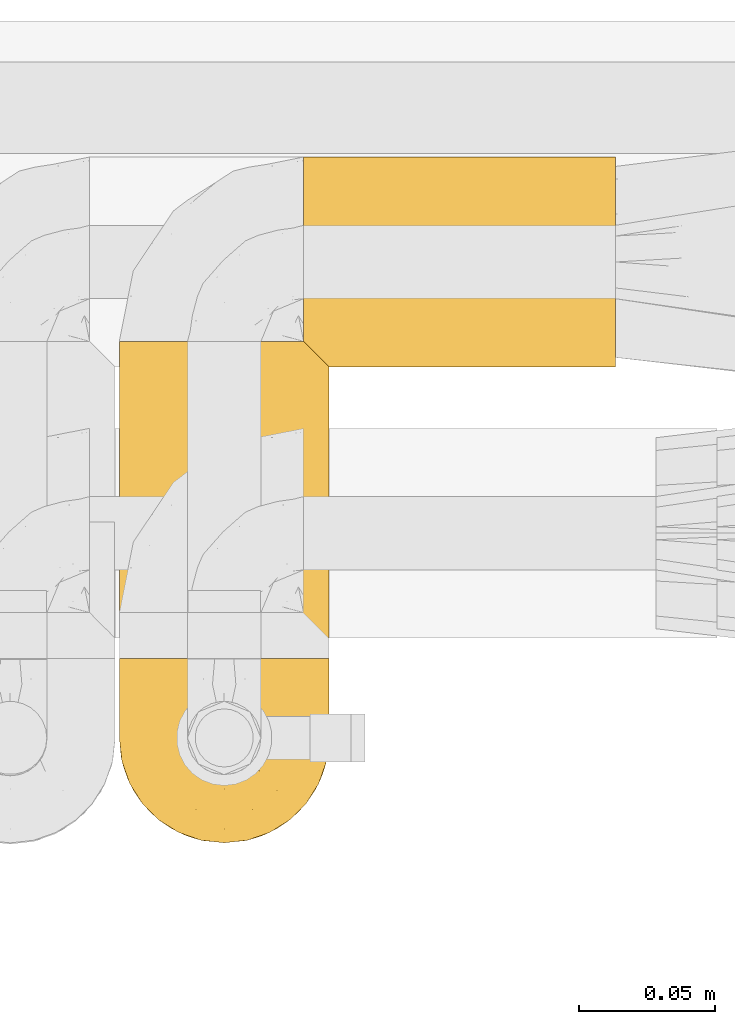
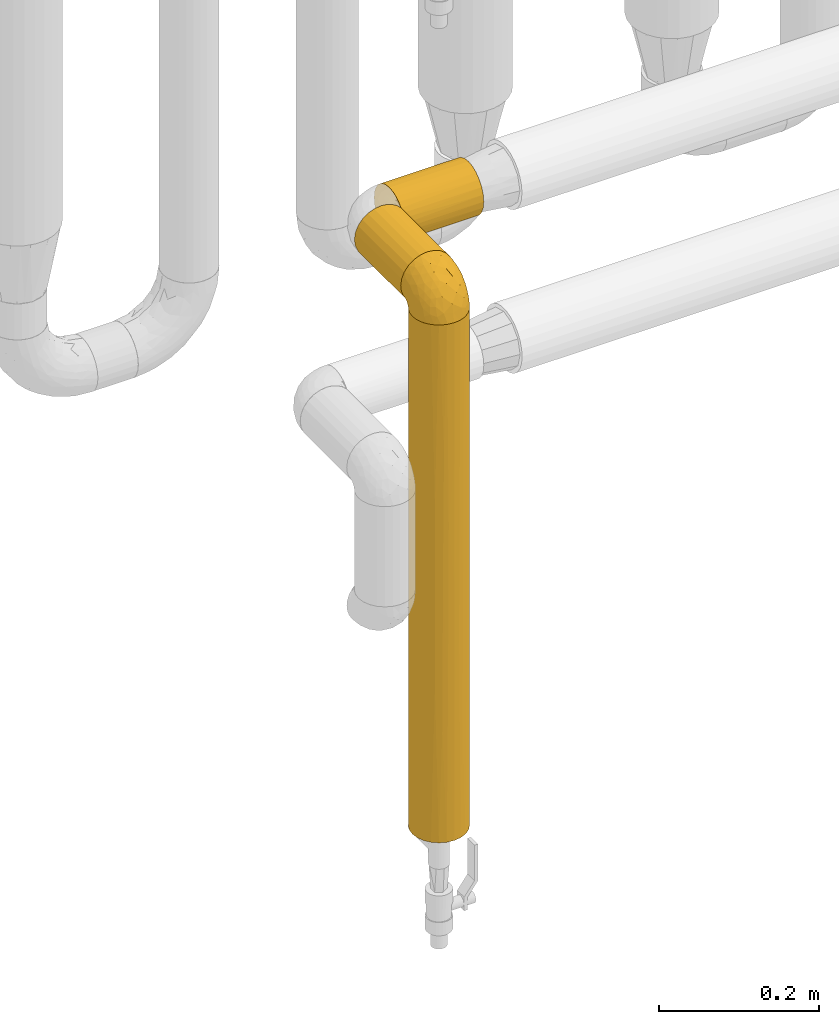
# One storey, part 467 of 827: 4 coverings.
"""IFC2X3 building model written with IfcOpenShell, lengths in millimetres."""

from ifc_helpers import new_model, entity, si_unit, converted_unit, derived_unit, direction, frame, origin, place, context, subcontext, project, spatial, faceted_brep, element, save


model = new_model("IFC2X3")

# Units and contexts
model_context = context("Model", 3, precision=0.01, world=origin(), true_north=direction((6.12303176911189e-17, 1.0)))
body_context = subcontext(model_context, "Body", "Model", "MODEL_VIEW")
ifc_project = project(units=[si_unit("LENGTHUNIT", "METRE", prefix="MILLI"), si_unit("AREAUNIT", "SQUARE_METRE"), si_unit("VOLUMEUNIT", "CUBIC_METRE"), converted_unit("PLANEANGLEUNIT", "DEGREE", entity("IfcRatioMeasure", 0.0174532925199433), si_unit("PLANEANGLEUNIT", "RADIAN"), dimensions=[0, 0, 0, 0, 0, 0, 0]), si_unit("MASSUNIT", "GRAM", prefix="KILO"), derived_unit("MASSDENSITYUNIT", [(si_unit("MASSUNIT", "GRAM", prefix="KILO"), 1), (si_unit("LENGTHUNIT", "METRE"), -3)]), derived_unit("MOMENTOFINERTIAUNIT", [(si_unit("LENGTHUNIT", "METRE"), 4)]), si_unit("TIMEUNIT", "SECOND"), si_unit("FREQUENCYUNIT", "HERTZ"), si_unit("THERMODYNAMICTEMPERATUREUNIT", "DEGREE_CELSIUS"), derived_unit("THERMALTRANSMITTANCEUNIT", [(si_unit("MASSUNIT", "GRAM", prefix="KILO"), 1), (si_unit("THERMODYNAMICTEMPERATUREUNIT", "KELVIN"), -1), (si_unit("TIMEUNIT", "SECOND"), -3)]), derived_unit("VOLUMETRICFLOWRATEUNIT", [(si_unit("LENGTHUNIT", "METRE"), 3), (si_unit("TIMEUNIT", "SECOND"), -1)]), derived_unit("MASSFLOWRATEUNIT", [(si_unit("MASSUNIT", "GRAM", prefix="KILO"), 1), (si_unit("TIMEUNIT", "SECOND"), -1)]), derived_unit("ROTATIONALFREQUENCYUNIT", [(si_unit("TIMEUNIT", "SECOND"), -1)]), si_unit("ELECTRICCURRENTUNIT", "AMPERE"), si_unit("ELECTRICVOLTAGEUNIT", "VOLT"), si_unit("POWERUNIT", "WATT"), si_unit("FORCEUNIT", "NEWTON", prefix="KILO"), si_unit("ILLUMINANCEUNIT", "LUX"), si_unit("LUMINOUSFLUXUNIT", "LUMEN"), si_unit("LUMINOUSINTENSITYUNIT", "CANDELA"), derived_unit("USERDEFINED", [(si_unit("MASSUNIT", "GRAM", prefix="KILO"), -1), (si_unit("LENGTHUNIT", "METRE"), -2), (si_unit("TIMEUNIT", "SECOND"), 3), (si_unit("LUMINOUSFLUXUNIT", "LUMEN"), 1)]), derived_unit("LINEARVELOCITYUNIT", [(si_unit("LENGTHUNIT", "METRE"), 1), (si_unit("TIMEUNIT", "SECOND"), -1)]), si_unit("PRESSUREUNIT", "PASCAL"), derived_unit("USERDEFINED", [(si_unit("LENGTHUNIT", "METRE"), -2), (si_unit("MASSUNIT", "GRAM", prefix="KILO"), 1), (si_unit("TIMEUNIT", "SECOND"), -2)]), derived_unit("LINEARFORCEUNIT", [(si_unit("MASSUNIT", "GRAM", prefix="KILO"), 1), (si_unit("LENGTHUNIT", "METRE"), 1), (si_unit("TIMEUNIT", "SECOND"), -2), (si_unit("LENGTHUNIT", "METRE"), -1)]), derived_unit("PLANARFORCEUNIT", [(si_unit("MASSUNIT", "GRAM", prefix="KILO"), 1), (si_unit("LENGTHUNIT", "METRE"), 1), (si_unit("TIMEUNIT", "SECOND"), -2), (si_unit("LENGTHUNIT", "METRE"), -2)])], contexts=[model_context])

# Site, building, storey
site_placement = place(None, origin())
site = spatial("IfcSite", under=ifc_project, at=site_placement, CompositionType="ELEMENT")
building_placement = place(site_placement, origin())
building = spatial("IfcBuilding", under=site, at=building_placement, CompositionType="ELEMENT")
storey_placement = place(building_placement, frame((0.0, 0.0, 28200.0)))
storey = spatial("IfcBuildingStorey", under=building, at=storey_placement, Name="08", CompositionType="ELEMENT", Elevation=28200.0)

# Coverings
covering_1_placement = place(storey_placement, frame((58529.6, 16332.35, 1210.0)))
element("IfcCovering", 1, at=covering_1_placement, inside=storey, Name=":ADSK_", ObjectType=":ADSK_", PredefinedType="INSULATION", context=body_context, shape_type="Brep", body=[
    faceted_brep([(9.31, 1.6, 16.91), (14.94, 1.6, 10.9), (65.05, 1.6, 10.9), (70.68, 1.6, 16.91), (74.9, 1.6, 23.98), (77.51, 1.6, 31.79), (78.4, 1.6, 40.0), (77.09, 1.6, 49.93), (73.25, 1.6, 59.2), (67.15, 1.6, 67.15), (59.2, 1.6, 73.25), (49.93, 1.6, 77.09), (40.0, 1.6, 78.4), (30.06, 1.6, 77.09), (20.8, 1.6, 73.25), (12.84, 1.6, 67.15), (6.74, 1.6, 59.2), (2.9, 1.6, 49.93), (1.6, 1.6, 40.0), (2.48, 1.6, 31.79), (5.09, 1.6, 23.98), (30.06, 117.77, 2.9), (20.8, 117.77, 6.74), (12.84, 117.77, 12.84), (6.74, 117.77, 20.8), (2.9, 117.77, 30.06), (1.6, 117.77, 40.0), (2.9, 117.77, 49.93), (6.74, 117.77, 59.2), (12.84, 117.77, 67.15), (20.8, 117.77, 73.25), (30.06, 117.77, 77.09), (40.0, 117.77, 78.4), (48.2, 117.77, 77.51), (56.01, 117.77, 74.9), (63.08, 117.77, 70.68), (69.1, 117.77, 65.05), (69.1, 117.77, 14.94), (63.08, 117.77, 9.31), (56.01, 117.77, 5.09), (48.2, 117.77, 2.48), (40.0, 117.77, 1.6), (26.63, 8.5, 4.0), (33.21, 10.29, 2.2), (40.0, 10.9, 1.6), (20.48, 5.57, 6.92), (46.78, 10.29, 2.2), (53.36, 8.5, 4.0), (59.51, 5.57, 6.92), (73.07, 113.8, 20.48), (76.0, 110.87, 26.63), (77.79, 109.08, 33.21), (78.4, 108.47, 40.0), (77.79, 109.08, 46.78), (76.0, 110.87, 53.36), (73.07, 113.8, 59.51)], [[[0, 1, 2, 3, 4, 5, 6, 7, 8, 9, 10, 11, 12, 13, 14, 15, 16, 17, 18, 19, 20]], [[21, 22, 23, 24, 25, 26, 27, 28, 29, 30, 31, 32, 33, 34, 35, 36, 37, 38, 39, 40, 41]], [[26, 25, 19]], [[25, 24, 20]], [[0, 24, 23]], [[19, 18, 26]], [[20, 19, 25]], [[24, 0, 20]], [[23, 1, 0]], [[42, 22, 21]], [[21, 41, 43]], [[44, 43, 41]], [[45, 1, 22]], [[43, 42, 21]], [[45, 22, 42]], [[22, 1, 23]], [[46, 41, 40]], [[47, 40, 39]], [[48, 39, 38]], [[46, 44, 41]], [[48, 47, 39]], [[2, 48, 38]], [[46, 40, 47]], [[38, 37, 2]], [[37, 49, 3]], [[50, 51, 5]], [[49, 50, 4]], [[3, 49, 4]], [[51, 6, 5]], [[5, 4, 50]], [[6, 51, 52]], [[37, 3, 2]], [[53, 54, 7]], [[55, 36, 8]], [[54, 55, 8]], [[52, 53, 6]], [[6, 53, 7]], [[54, 8, 7]], [[36, 9, 8]], [[10, 35, 34]], [[11, 34, 33]], [[12, 33, 32]], [[9, 35, 10]], [[10, 34, 11]], [[33, 12, 11]], [[35, 9, 36]], [[13, 12, 32, 31]], [[14, 13, 31, 30]], [[30, 29, 15, 14]], [[17, 16, 28, 27]], [[18, 17, 27, 26]], [[29, 28, 16, 15]], [[45, 42, 43, 44, 46, 47, 48, 2, 1]], [[36, 55, 54, 53, 52, 51, 50, 49, 37]]]),
])
covering_2_placement = place(storey_placement, frame((58529.55, 16264.8, 1219.3)))
element("IfcCovering", 2, at=covering_2_placement, inside=storey, Name=":ADSK_", ObjectType=":ADSK_", PredefinedType="INSULATION", context=body_context, shape_type="Brep", body=[
    faceted_brep([(74.68, 23.36, 1.6), (70.1, 16.07, 1.6), (64.01, 9.98, 1.6), (56.72, 5.4, 1.6), (48.6, 2.56, 1.6), (40.05, 1.6, 1.6), (31.49, 2.56, 1.6), (23.36, 5.41, 1.6), (16.07, 9.99, 1.6), (9.98, 16.08, 1.6), (5.4, 23.37, 1.6), (2.56, 31.49, 1.6), (1.6, 40.05, 1.6), (2.46, 48.15, 1.6), (5.01, 55.88, 1.6), (9.13, 62.9, 1.6), (14.62, 68.89, 1.6), (16.82, 68.89, 1.6), (18.56, 68.89, 1.6), (20.52, 68.89, 1.6), (22.49, 68.89, 1.6), (24.46, 68.89, 1.6), (26.42, 68.89, 1.6), (28.39, 68.89, 1.6), (30.36, 68.89, 1.6), (32.55, 68.89, 1.6), (34.75, 68.89, 1.6), (36.94, 68.89, 1.6), (39.13, 68.89, 1.6), (41.33, 68.89, 1.6), (43.52, 68.89, 1.6), (45.72, 68.89, 1.6), (47.91, 68.89, 1.6), (50.11, 68.89, 1.6), (52.3, 68.89, 1.6), (54.49, 68.89, 1.6), (56.69, 68.89, 1.6), (58.88, 68.89, 1.6), (61.08, 68.89, 1.6), (63.27, 68.89, 1.6), (65.47, 68.89, 1.6), (70.97, 62.89, 1.6), (75.09, 55.86, 1.6), (77.64, 48.13, 1.6), (78.5, 40.05, 1.6), (77.53, 31.49, 1.6), (14.62, 69.15, 1.85), (9.12, 69.15, 7.85), (5.0, 69.15, 14.87), (2.46, 69.15, 22.6), (1.6, 69.15, 30.7), (2.91, 69.15, 40.65), (6.75, 69.15, 49.92), (12.86, 69.15, 57.88), (20.82, 69.15, 63.99), (30.09, 69.15, 67.84), (40.05, 69.15, 69.15), (50.0, 69.15, 67.84), (59.27, 69.15, 63.99), (67.23, 69.15, 57.88), (73.34, 69.15, 49.92), (77.19, 69.15, 40.65), (78.5, 69.15, 30.7), (77.63, 69.15, 22.6), (75.09, 69.15, 14.87), (70.97, 69.15, 7.85), (65.47, 69.15, 1.85), (63.27, 69.15, 1.85), (62.29, 69.15, 1.85), (60.7, 69.15, 1.85), (59.11, 69.15, 1.85), (57.52, 69.15, 1.85), (55.93, 69.15, 1.85), (54.34, 69.15, 1.85), (52.76, 69.15, 1.85), (51.17, 69.15, 1.85), (49.58, 69.15, 1.85), (47.99, 69.15, 1.85), (46.4, 69.15, 1.85), (44.81, 69.15, 1.85), (43.22, 69.15, 1.85), (41.63, 69.15, 1.85), (40.05, 69.15, 1.85), (38.46, 69.15, 1.85), (36.87, 69.15, 1.85), (35.28, 69.15, 1.85), (33.69, 69.15, 1.85), (32.1, 69.15, 1.85), (30.51, 69.15, 1.85), (28.92, 69.15, 1.85), (27.33, 69.15, 1.85), (25.37, 69.15, 1.85), (23.4, 69.15, 1.85), (21.21, 69.15, 1.85), (19.01, 69.15, 1.85), (16.82, 69.15, 1.85), (42.32, 68.96, 1.77), (44.02, 68.97, 1.78), (47.13, 68.97, 1.77), (48.74, 68.97, 1.77), (23.57, 68.95, 1.76), (25.13, 68.96, 1.77), (61.34, 68.98, 1.79), (22.02, 68.97, 1.78), (29.72, 68.97, 1.78), (56.73, 68.98, 1.78), (55.14, 68.97, 1.78), (37.66, 68.97, 1.78), (64.12, 68.94, 1.74), (28.13, 68.98, 1.78), (26.62, 68.98, 1.78), (31.46, 68.96, 1.77), (16.16, 68.97, 1.78), (39.16, 68.98, 1.78), (50.37, 68.98, 1.78), (17.69, 68.97, 1.77), (19.17, 68.96, 1.77), (62.78, 68.97, 1.77), (58.35, 68.97, 1.78), (45.53, 68.98, 1.78), (59.91, 68.96, 1.77), (65.47, 68.97, 1.77), (65.47, 68.94, 1.72), (65.47, 68.92, 1.66), (14.62, 68.97, 1.77), (14.62, 69.02, 1.8), (14.62, 69.08, 1.82), (20.59, 68.98, 1.79), (32.99, 68.97, 1.78), (34.48, 68.98, 1.79), (51.91, 68.97, 1.78), (65.47, 69.08, 1.82), (65.47, 69.02, 1.8), (53.48, 68.96, 1.76), (14.62, 68.92, 1.66), (14.62, 68.94, 1.72), (40.77, 68.97, 1.78), (35.97, 68.96, 1.77), (7.84, 67.02, 9.41), (3.53, 63.33, 17.65), (8.32, 64.61, 7.41), (1.6, 49.27, 21.47), (2.19, 51.4, 15.21), (1.6, 43.94, 16.15), (1.6, 61.87, 28.75), (4.57, 61.54, 13.67), (3.96, 57.95, 12.79), (2.28, 56.12, 19.18), (1.6, 63.4, 29.16), (7.69, 65.41, 9.04), (3.53, 53.1, 7.41), (8.32, 63.04, 5.74), (7.84, 61.33, 3.72), (1.6, 41.99, 8.87), (1.6, 54.6, 26.8), (4.34, 56.6, 9.53), (1.6, 41.58, 7.34), (29.63, 13.72, 37.63), (27.34, 5.82, 17.92), (40.05, 6.74, 27.45), (2.39, 58.82, 37.01), (2.43, 51.58, 34.22), (9.07, 42.09, 45.87), (16.64, 46.12, 56.57), (9.54, 55.56, 52.31), (4.52, 52.38, 42.07), (4.52, 61.54, 44.74), (7.49, 23.76, 21.49), (7.49, 20.5, 11.02), (12.85, 14.64, 15.64), (2.35, 41.77, 26.02), (22.66, 16.28, 36.59), (32.9, 49.4, 65.49), (25.33, 52.34, 63.99), (40.05, 4.3, 15.2), (16.64, 58.67, 60.27), (19.99, 25.26, 45.25), (16.37, 20.17, 35.21), (3.26, 34.7, 22.52), (3.75, 28.67, 12.03), (19.58, 8.62, 13.32), (7.5, 33.37, 35.9), (4.04, 41.35, 33.87), (13.94, 17.15, 25.73), (19.58, 12.68, 26.34), (28.21, 21.47, 46.78), (24.75, 41.11, 59.54), (31.42, 37.53, 60.18), (26.2, 30.64, 53.93), (33.36, 26.66, 53.36), (40.05, 21.38, 49.36), (40.05, 14.06, 38.4), (40.05, 55.54, 66.44), (16.14, 35.17, 50.09), (12.85, 29.04, 41.08), (10.47, 24.34, 31.14), (6.49, 29.33, 28.19), (40.05, 43.3, 64.0), (40.05, 32.34, 56.68), (75.57, 57.75, 43.9), (47.37, 49.41, 65.46), (52.91, 27.85, 52.22), (50.46, 13.7, 37.61), (67.23, 14.63, 15.64), (60.5, 8.61, 13.31), (70.55, 48.85, 50.02), (63.45, 54.13, 59.28), (62.61, 37.84, 53.05), (72.6, 23.75, 21.48), (72.6, 20.49, 11.01), (76.34, 28.66, 12.03), (59.34, 20.83, 41.02), (77.76, 55.15, 35.39), (78.5, 54.6, 26.8), (78.5, 61.87, 28.75), (78.5, 41.58, 7.34), (53.16, 57.58, 65.81), (70.55, 59.91, 53.28), (48.88, 36.94, 59.8), (54.76, 45.72, 61.82), (52.74, 5.82, 17.91), (71.93, 37.91, 41.4), (75.79, 50.18, 40.48), (60.5, 12.67, 26.34), (77.86, 49.29, 31.68), (77.64, 42.64, 27.68), (78.5, 43.94, 16.15), (78.5, 49.27, 21.47), (67.23, 19.45, 28.05), (76.82, 34.7, 22.54), (78.5, 41.99, 8.87), (77.8, 62.29, 37.3), (67.23, 29.01, 41.07), (73.2, 31.47, 32.24), (67.66, 37.18, 47.4), (75.99, 43.45, 35.77), (76.57, 63.33, 17.65), (73.21, 67.23, 11.06), (71.93, 66.07, 8.55), (71.07, 65.22, 6.63), (75.09, 61.99, 12.77), (76.13, 57.95, 12.79), (76.57, 53.09, 7.41), (77.69, 56.84, 18.97), (72.26, 61.33, 3.72), (71.77, 63.06, 5.76), (77.9, 51.41, 15.21), (75.75, 56.61, 9.52)], [[[0, 1, 2, 3, 4, 5, 6, 7, 8, 9, 10, 11, 12, 13, 14, 15, 16, 17, 18, 19, 20, 21, 22, 23, 24, 25, 26, 27, 28, 29, 30, 31, 32, 33, 34, 35, 36, 37, 38, 39, 40, 41, 42, 43, 44, 45]], [[46, 47, 48, 49, 50, 51, 52, 53, 54, 55, 56, 57, 58, 59, 60, 61, 62, 63, 64, 65, 66, 67, 68, 69, 70, 71, 72, 73, 74, 75, 76, 77, 78, 79, 80, 81, 82, 83, 84, 85, 86, 87, 88, 89, 90, 91, 92, 93, 94, 95]], [[96, 97, 30]], [[98, 77, 99]], [[100, 101, 21]], [[69, 68, 102]], [[20, 19, 103]], [[24, 23, 104]], [[20, 103, 100]], [[72, 105, 106]], [[84, 83, 107]], [[89, 88, 104]], [[108, 67, 66]], [[109, 110, 90]], [[111, 25, 24]], [[112, 17, 16]], [[82, 113, 83]], [[109, 23, 22]], [[114, 76, 75]], [[105, 36, 106]], [[104, 111, 24]], [[18, 115, 116]], [[97, 96, 80]], [[67, 108, 117]], [[105, 71, 118]], [[31, 97, 119]], [[102, 120, 69]], [[108, 121, 122, 123, 40]], [[112, 95, 115]], [[17, 115, 18]], [[94, 116, 115]], [[117, 68, 67]], [[38, 117, 39]], [[112, 124, 125, 126, 46]], [[17, 112, 115]], [[70, 120, 118]], [[39, 117, 108]], [[120, 38, 37]], [[120, 37, 118]], [[120, 70, 69]], [[116, 94, 127]], [[128, 86, 129]], [[117, 38, 102]], [[74, 130, 75]], [[99, 33, 32]], [[115, 95, 94]], [[39, 108, 40]], [[108, 66, 131, 132, 121]], [[105, 72, 71]], [[118, 37, 36]], [[71, 70, 118]], [[35, 106, 36]], [[36, 105, 118]], [[35, 133, 106]], [[74, 73, 133]], [[106, 133, 73]], [[99, 114, 33]], [[133, 35, 34]], [[73, 72, 106]], [[95, 112, 46]], [[112, 16, 134, 135, 124]], [[130, 114, 75]], [[99, 76, 114]], [[114, 130, 33]], [[34, 33, 130]], [[78, 77, 98]], [[98, 119, 78]], [[130, 133, 34]], [[133, 130, 74]], [[79, 97, 80]], [[98, 99, 32]], [[98, 32, 31]], [[77, 76, 99]], [[97, 79, 119]], [[136, 96, 29]], [[30, 97, 31]], [[136, 29, 28]], [[81, 80, 96]], [[29, 96, 30]], [[31, 119, 98]], [[119, 79, 78]], [[96, 136, 81]], [[82, 81, 136]], [[113, 107, 83]], [[84, 107, 137]], [[107, 27, 137]], [[113, 28, 107]], [[27, 107, 28]], [[85, 84, 137]], [[137, 27, 26]], [[113, 136, 28]], [[136, 113, 82]], [[109, 89, 104]], [[86, 85, 129]], [[89, 109, 90]], [[111, 87, 128]], [[26, 129, 137]], [[88, 111, 104]], [[25, 111, 128]], [[22, 110, 109]], [[23, 109, 104]], [[110, 91, 90]], [[100, 92, 101]], [[110, 22, 101]], [[91, 110, 101]], [[116, 19, 18]], [[111, 88, 87]], [[127, 103, 19]], [[25, 128, 26]], [[86, 128, 87]], [[128, 129, 26]], [[137, 129, 85]], [[120, 102, 38]], [[117, 102, 68]], [[91, 101, 92]], [[21, 101, 22]], [[93, 92, 103]], [[100, 21, 20]], [[100, 103, 92]], [[127, 93, 103]], [[93, 127, 94]], [[116, 127, 19]], [[126, 138, 47]], [[48, 138, 139]], [[140, 125, 124]], [[141, 142, 143]], [[144, 49, 139]], [[145, 140, 146]], [[48, 139, 49]], [[139, 145, 147]], [[49, 144, 148, 50]], [[126, 125, 149]], [[14, 13, 150]], [[151, 146, 140]], [[149, 140, 145]], [[152, 151, 135]], [[152, 14, 150]], [[16, 15, 134]], [[13, 153, 150]], [[124, 151, 140]], [[141, 147, 142]], [[14, 152, 15]], [[15, 152, 134]], [[47, 46, 126]], [[139, 154, 144]], [[138, 48, 47]], [[125, 140, 149]], [[135, 134, 152]], [[146, 155, 142]], [[145, 146, 147]], [[149, 139, 138]], [[147, 141, 154]], [[147, 146, 142]], [[139, 147, 154]], [[139, 149, 145]], [[149, 138, 126]], [[155, 146, 151]], [[150, 143, 142]], [[152, 155, 151]], [[150, 142, 155]], [[13, 12, 156, 153]], [[153, 143, 150]], [[152, 150, 155]], [[151, 124, 135]], [[157, 158, 159]], [[160, 154, 161]], [[162, 163, 164]], [[165, 166, 160]], [[167, 168, 169]], [[141, 170, 161]], [[156, 12, 11]], [[158, 157, 171]], [[172, 55, 173]], [[158, 6, 174]], [[175, 54, 53]], [[52, 166, 164]], [[52, 164, 53]], [[54, 175, 173]], [[166, 52, 51]], [[176, 177, 171]], [[178, 143, 179]], [[156, 11, 179]], [[8, 7, 180]], [[169, 9, 8]], [[179, 143, 153, 156]], [[179, 11, 10]], [[168, 179, 10]], [[181, 162, 182]], [[179, 167, 178]], [[183, 184, 177]], [[183, 169, 184]], [[176, 171, 185]], [[172, 186, 187]], [[158, 7, 6]], [[159, 158, 174]], [[184, 180, 158]], [[54, 173, 55]], [[180, 169, 8]], [[188, 189, 187]], [[9, 168, 10]], [[186, 188, 187]], [[190, 157, 159, 191]], [[55, 172, 192]], [[176, 193, 194]], [[161, 170, 182]], [[162, 164, 165]], [[175, 164, 163]], [[51, 50, 148]], [[167, 195, 196]], [[178, 182, 170]], [[6, 5, 174]], [[158, 180, 7]], [[169, 180, 184]], [[169, 168, 9]], [[179, 168, 167]], [[182, 162, 165]], [[162, 194, 193]], [[161, 165, 160]], [[195, 181, 196]], [[192, 172, 197]], [[192, 56, 55]], [[189, 190, 198]], [[198, 197, 187]], [[172, 187, 197]], [[185, 189, 188]], [[198, 187, 189]], [[186, 172, 173]], [[173, 163, 186]], [[193, 186, 163]], [[176, 185, 188]], [[185, 157, 190]], [[188, 186, 193]], [[177, 176, 194]], [[188, 193, 176]], [[162, 193, 163]], [[195, 177, 194]], [[171, 177, 184]], [[181, 195, 194]], [[183, 167, 169]], [[162, 181, 194]], [[196, 182, 178]], [[158, 171, 184]], [[171, 157, 185]], [[177, 195, 183]], [[167, 183, 195]], [[182, 196, 181]], [[178, 170, 143]], [[178, 167, 196]], [[164, 175, 53]], [[173, 175, 163]], [[160, 51, 148]], [[164, 166, 165]], [[51, 160, 166]], [[160, 148, 144, 154]], [[141, 161, 154]], [[182, 165, 161]], [[190, 189, 185]], [[143, 170, 141]], [[60, 199, 61]], [[197, 200, 192]], [[201, 190, 202]], [[200, 57, 192]], [[203, 204, 2]], [[205, 206, 207]], [[208, 209, 210]], [[211, 207, 201]], [[212, 213, 214]], [[45, 215, 210]], [[216, 206, 58]], [[45, 44, 215]], [[59, 217, 60]], [[60, 217, 199]], [[0, 45, 210]], [[218, 201, 219]], [[202, 159, 220]], [[205, 221, 222]], [[223, 204, 203]], [[1, 203, 2]], [[57, 200, 216]], [[220, 3, 204]], [[220, 174, 4]], [[1, 0, 209]], [[212, 224, 213]], [[225, 226, 227]], [[228, 223, 203]], [[208, 210, 229]], [[210, 226, 229]], [[3, 220, 4]], [[58, 206, 59]], [[209, 203, 1]], [[202, 220, 223]], [[228, 203, 208]], [[202, 211, 201]], [[3, 2, 204]], [[202, 190, 191, 159]], [[210, 215, 230, 226]], [[199, 212, 231]], [[232, 233, 221]], [[233, 208, 229]], [[207, 206, 219]], [[217, 206, 205]], [[227, 224, 225]], [[233, 232, 228]], [[201, 207, 219]], [[234, 232, 221]], [[218, 219, 200]], [[202, 223, 211]], [[174, 220, 159]], [[174, 5, 4]], [[61, 231, 62]], [[220, 204, 223]], [[210, 209, 0]], [[203, 209, 208]], [[225, 233, 229]], [[224, 227, 213]], [[221, 233, 235]], [[57, 56, 192]], [[198, 218, 197]], [[200, 219, 216]], [[201, 198, 190]], [[197, 218, 200]], [[198, 201, 218]], [[206, 216, 219]], [[58, 57, 216]], [[231, 212, 214]], [[222, 212, 199]], [[228, 211, 223]], [[207, 211, 232]], [[62, 231, 214]], [[199, 231, 61]], [[233, 228, 208]], [[211, 228, 232]], [[222, 221, 235]], [[234, 205, 207]], [[206, 217, 59]], [[199, 217, 205]], [[205, 222, 199]], [[224, 222, 235]], [[222, 224, 212]], [[224, 235, 225]], [[233, 225, 235]], [[226, 225, 229]], [[205, 234, 221]], [[207, 232, 234]], [[63, 214, 236]], [[214, 213, 236]], [[214, 63, 62]], [[237, 236, 238]], [[238, 132, 131]], [[236, 237, 64]], [[239, 240, 241]], [[63, 236, 64]], [[131, 66, 65]], [[237, 131, 65]], [[242, 230, 43]], [[237, 65, 64]], [[239, 121, 132]], [[42, 242, 43]], [[241, 240, 243]], [[41, 123, 244]], [[43, 230, 215, 44]], [[244, 122, 245]], [[227, 246, 243]], [[241, 247, 245]], [[121, 239, 245]], [[41, 40, 123]], [[132, 238, 239]], [[244, 42, 41]], [[131, 237, 238]], [[240, 239, 238]], [[245, 239, 241]], [[247, 241, 246]], [[247, 244, 245]], [[238, 236, 240]], [[243, 236, 213]], [[236, 243, 240]], [[227, 226, 246]], [[243, 213, 227]], [[242, 246, 226]], [[243, 246, 241]], [[246, 242, 247]], [[244, 247, 242]], [[242, 226, 230]], [[42, 244, 242]], [[122, 244, 123]], [[122, 121, 245]]]),
])
covering_3_placement = place(storey_placement, frame((58529.6, 16264.85, 429.0)))
element("IfcCovering", 3, at=covering_3_placement, inside=storey, Name=":ADSK_", ObjectType=":ADSK_", PredefinedType="INSULATION", context=body_context, shape_type="Brep", body=[
    faceted_brep([(77.09, 30.06, 791.9), (78.4, 40.0, 791.9), (77.51, 48.2, 791.9), (74.9, 56.01, 791.9), (70.68, 63.08, 791.9), (65.05, 69.1, 791.9), (14.94, 69.1, 791.9), (9.31, 63.08, 791.9), (5.09, 56.01, 791.9), (2.48, 48.2, 791.9), (1.6, 40.0, 791.9), (2.9, 30.06, 791.9), (6.74, 20.8, 791.9), (12.84, 12.84, 791.9), (20.8, 6.74, 791.9), (30.06, 2.9, 791.9), (40.0, 1.6, 791.9), (49.93, 2.9, 791.9), (59.2, 6.74, 791.9), (67.15, 12.84, 791.9), (73.25, 20.8, 791.9), (73.25, 20.8, 0.0), (67.15, 12.84, 0.0), (59.2, 6.74, 0.0), (49.93, 2.9, 0.0), (40.0, 1.6, 0.0), (30.06, 2.9, 0.0), (20.8, 6.74, 0.0), (12.84, 12.84, 0.0), (6.74, 20.8, 0.0), (2.9, 30.06, 0.0), (1.6, 40.0, 0.0), (2.9, 49.93, 0.0), (6.74, 59.2, 0.0), (12.84, 67.15, 0.0), (20.8, 73.25, 0.0), (30.06, 77.09, 0.0), (40.0, 78.4, 0.0), (49.93, 77.09, 0.0), (59.2, 73.25, 0.0), (67.15, 67.15, 0.0), (73.25, 59.2, 0.0), (77.09, 49.93, 0.0), (78.4, 40.0, 0.0), (77.09, 30.06, 0.0), (63.37, 9.53, 277.46), (55.27, 4.77, 613.75), (48.39, 2.52, 549.84), (53.38, 4.0, 186.32), (54.69, 4.52, 395.95), (47.49, 2.33, 306.16), (40.0, 1.6, 216.37), (75.99, 26.61, 605.58), (77.66, 32.5, 485.74), (40.0, 1.6, 395.95), (40.0, 1.6, 575.53), (63.37, 9.53, 555.07), (70.46, 16.62, 236.83), (77.47, 31.6, 242.06), (75.23, 24.72, 178.15), (70.46, 16.62, 514.44), (78.4, 40.0, 395.95), (75.47, 25.3, 395.95), (78.4, 40.0, 575.53), (78.4, 40.0, 216.37), (78.4, 40.0, 359.15), (72.1, 61.06, 200.25), (76.43, 52.12, 267.79), (76.41, 52.17, 543.55), (68.03, 66.24, 555.1), (62.48, 71.13, 603.35), (57.06, 74.39, 494.19), (62.59, 71.04, 392.47), (68.42, 65.82, 317.97), (72.98, 59.66, 404.72), (72.98, 59.66, 616.57), (40.0, 78.4, 566.22), (46.78, 77.79, 783.2), (50.2, 77.01, 476.01), (53.36, 76.0, 785.0), (40.0, 78.4, 349.85), (46.6, 77.82, 213.32), (59.51, 73.07, 787.93), (40.0, 78.4, 782.6), (54.39, 75.6, 235.78), (64.14, 69.86, 182.83), (25.6, 75.6, 235.78), (22.93, 74.39, 494.19), (29.79, 77.01, 476.01), (3.56, 52.12, 267.79), (33.39, 77.82, 213.32), (11.96, 66.24, 555.1), (17.52, 71.13, 603.35), (17.4, 71.04, 392.47), (7.01, 59.66, 404.72), (7.89, 61.06, 200.25), (26.63, 76.0, 785.0), (33.21, 77.79, 783.2), (3.58, 52.17, 543.55), (1.6, 40.0, 359.15), (1.6, 40.0, 575.53), (11.58, 65.82, 317.97), (15.86, 69.86, 182.83), (20.48, 73.07, 787.93), (7.01, 59.66, 616.57), (4.52, 25.3, 236.83), (16.62, 9.53, 236.83), (24.72, 4.77, 178.15), (2.26, 32.88, 467.34), (2.21, 33.14, 231.38), (9.53, 16.62, 620.42), (4.52, 25.3, 514.44), (9.53, 16.62, 171.48), (9.53, 16.62, 395.95), (25.3, 4.52, 395.95), (16.62, 9.53, 514.44), (31.6, 2.52, 242.06), (26.61, 4.0, 605.58), (32.5, 2.33, 485.74)], [[[0, 1, 2, 3, 4, 5, 6, 7, 8, 9, 10, 11, 12, 13, 14, 15, 16, 17, 18, 19, 20]], [[21, 22, 23, 24, 25, 26, 27, 28, 29, 30, 31, 32, 33, 34, 35, 36, 37, 38, 39, 40, 41, 42, 43, 44]], [[23, 22, 45]], [[46, 17, 47]], [[48, 49, 50]], [[51, 24, 50]], [[0, 52, 53]], [[54, 50, 47]], [[50, 49, 47]], [[16, 55, 54, 47]], [[45, 56, 49]], [[18, 56, 19]], [[49, 48, 45]], [[22, 21, 57]], [[44, 58, 59]], [[57, 21, 59]], [[60, 56, 45]], [[61, 53, 58]], [[62, 52, 60]], [[57, 62, 60]], [[45, 22, 57]], [[19, 60, 20]], [[1, 0, 63]], [[56, 60, 19]], [[56, 18, 46]], [[62, 53, 52]], [[45, 57, 60]], [[53, 62, 58]], [[50, 54, 51]], [[51, 25, 24]], [[48, 50, 24]], [[46, 47, 49]], [[16, 47, 17]], [[24, 23, 48]], [[45, 48, 23]], [[56, 46, 49]], [[17, 46, 18]], [[0, 53, 63]], [[61, 63, 53]], [[43, 64, 65, 61, 58]], [[59, 58, 62]], [[43, 58, 44]], [[0, 20, 52]], [[60, 52, 20]], [[57, 59, 62]], [[44, 59, 21]], [[66, 67, 41]], [[2, 63, 68]], [[2, 68, 3]], [[69, 70, 5]], [[71, 70, 72]], [[72, 69, 73]], [[74, 68, 67]], [[67, 43, 42]], [[40, 73, 66]], [[74, 75, 68]], [[75, 4, 3]], [[67, 68, 65]], [[70, 69, 72]], [[41, 67, 42]], [[69, 5, 4]], [[75, 69, 4]], [[76, 77, 78]], [[67, 65, 64, 43]], [[77, 79, 78]], [[80, 81, 37]], [[5, 70, 82]], [[77, 76, 83]], [[71, 79, 82]], [[84, 81, 78]], [[85, 72, 73]], [[81, 84, 38]], [[71, 84, 78]], [[73, 69, 74]], [[71, 82, 70]], [[72, 85, 84]], [[79, 71, 78]], [[72, 84, 71]], [[39, 38, 84]], [[66, 73, 74]], [[85, 73, 40]], [[40, 39, 85]], [[84, 85, 39]], [[68, 75, 3]], [[69, 75, 74]], [[67, 66, 74]], [[40, 66, 41]], [[37, 81, 38]], [[78, 81, 80]], [[78, 80, 76]], [[63, 2, 1]], [[68, 63, 61, 65]], [[86, 87, 88]], [[89, 32, 31]], [[90, 37, 36]], [[91, 92, 93]], [[89, 94, 95]], [[96, 97, 88]], [[86, 93, 87]], [[98, 99, 100]], [[95, 94, 101]], [[96, 88, 87]], [[34, 101, 102]], [[97, 76, 88]], [[92, 6, 103]], [[91, 7, 6]], [[91, 101, 94]], [[104, 91, 94]], [[86, 90, 36]], [[89, 99, 98]], [[101, 91, 93]], [[98, 100, 9]], [[100, 10, 9]], [[7, 104, 8]], [[87, 93, 92]], [[8, 104, 98]], [[9, 8, 98]], [[99, 89, 31]], [[89, 98, 94]], [[92, 91, 6]], [[103, 96, 87]], [[89, 33, 32]], [[87, 92, 103]], [[90, 88, 80]], [[36, 35, 86]], [[86, 35, 102]], [[102, 101, 93]], [[95, 34, 33]], [[86, 102, 93]], [[35, 34, 102]], [[91, 104, 7]], [[98, 104, 94]], [[34, 95, 101]], [[89, 95, 33]], [[88, 90, 86]], [[37, 90, 80]], [[76, 97, 83]], [[76, 80, 88]], [[30, 29, 105]], [[106, 27, 107]], [[108, 99, 109]], [[110, 111, 105, 112, 113]], [[109, 31, 30]], [[28, 112, 29]], [[99, 108, 100]], [[110, 13, 12]], [[12, 11, 111]], [[114, 115, 106]], [[113, 112, 106, 115, 110]], [[26, 116, 107]], [[117, 115, 114]], [[54, 118, 116]], [[110, 115, 13]], [[27, 106, 28]], [[11, 100, 108]], [[14, 13, 115]], [[16, 15, 55]], [[114, 118, 117]], [[108, 109, 105]], [[118, 114, 116]], [[105, 29, 112]], [[15, 117, 118]], [[11, 10, 100]], [[105, 111, 108]], [[11, 108, 111]], [[31, 109, 99]], [[30, 105, 109]], [[15, 118, 55]], [[54, 55, 118]], [[25, 51, 54, 116]], [[107, 116, 114]], [[25, 116, 26]], [[15, 14, 117]], [[115, 117, 14]], [[106, 107, 114]], [[26, 107, 27]], [[111, 110, 12]], [[106, 112, 28]], [[82, 79, 77, 83, 97, 96, 103, 6, 5]]]),
])
covering_4_placement = place(storey_placement, frame((58597.1, 16439.23, 1210.0)))
element("IfcCovering", 4, at=covering_4_placement, inside=storey, Name=":ADSK_", ObjectType=":ADSK_", PredefinedType="INSULATION", context=body_context, shape_type="Brep", body=[
    faceted_brep([(1.6, 31.79, 2.48), (1.6, 23.98, 5.09), (1.6, 16.91, 9.31), (1.6, 10.9, 14.94), (1.6, 10.9, 65.05), (1.6, 16.91, 70.68), (1.6, 23.98, 74.9), (1.6, 31.79, 77.51), (1.6, 40.0, 78.4), (1.6, 49.93, 77.09), (1.6, 59.2, 73.25), (1.6, 67.15, 67.15), (1.6, 73.25, 59.2), (1.6, 77.09, 49.93), (1.6, 78.4, 40.0), (1.6, 77.09, 30.06), (1.6, 73.25, 20.8), (1.6, 67.15, 12.84), (1.6, 59.2, 6.74), (1.6, 49.93, 2.9), (1.6, 40.0, 1.6), (115.92, 20.8, 6.74), (115.92, 30.06, 2.9), (115.92, 40.0, 1.6), (115.92, 49.93, 2.9), (115.92, 59.2, 6.74), (115.92, 67.15, 12.84), (115.92, 73.25, 20.8), (115.92, 77.09, 30.06), (115.92, 78.4, 40.0), (115.92, 77.09, 49.93), (115.92, 73.25, 59.2), (115.92, 67.15, 67.15), (115.92, 59.2, 73.25), (115.92, 49.93, 77.09), (115.92, 40.0, 78.4), (115.92, 30.06, 77.09), (115.92, 20.8, 73.25), (115.92, 12.84, 67.15), (115.92, 6.74, 59.2), (115.92, 2.9, 49.93), (115.92, 1.6, 40.0), (115.92, 2.9, 30.06), (115.92, 6.74, 20.8), (115.92, 12.84, 12.84), (8.5, 4.0, 26.63), (10.29, 2.2, 33.21), (10.9, 1.6, 40.0), (5.57, 6.92, 20.48), (10.29, 2.2, 46.78), (8.5, 4.0, 53.36), (5.57, 6.92, 59.51)], [[[0, 1, 2, 3, 4, 5, 6, 7, 8, 9, 10, 11, 12, 13, 14, 15, 16, 17, 18, 19, 20]], [[21, 22, 23, 24, 25, 26, 27, 28, 29, 30, 31, 32, 33, 34, 35, 36, 37, 38, 39, 40, 41, 42, 43, 44]], [[28, 27, 16, 15]], [[29, 28, 15, 14]], [[27, 26, 17, 16]], [[19, 18, 25, 24]], [[20, 19, 24, 23]], [[26, 25, 18, 17]], [[0, 23, 22]], [[1, 22, 21]], [[2, 21, 44]], [[20, 23, 0]], [[0, 22, 1]], [[21, 2, 1]], [[44, 3, 2]], [[45, 43, 42]], [[42, 41, 46]], [[47, 46, 41]], [[48, 3, 43]], [[46, 45, 42]], [[48, 43, 45]], [[43, 3, 44]], [[49, 47, 41]], [[49, 41, 40]], [[50, 40, 39]], [[50, 49, 40]], [[4, 51, 39]], [[50, 39, 51]], [[39, 38, 4]], [[5, 38, 37]], [[6, 37, 36]], [[7, 36, 35]], [[5, 37, 6]], [[6, 36, 7]], [[35, 8, 7]], [[38, 5, 4]], [[9, 8, 35, 34]], [[10, 9, 34, 33]], [[33, 32, 11, 10]], [[13, 12, 31, 30]], [[14, 13, 30, 29]], [[32, 31, 12, 11]], [[3, 48, 45, 46, 47, 49, 50, 51, 4]]]),
])

save(model, "model.ifc")
